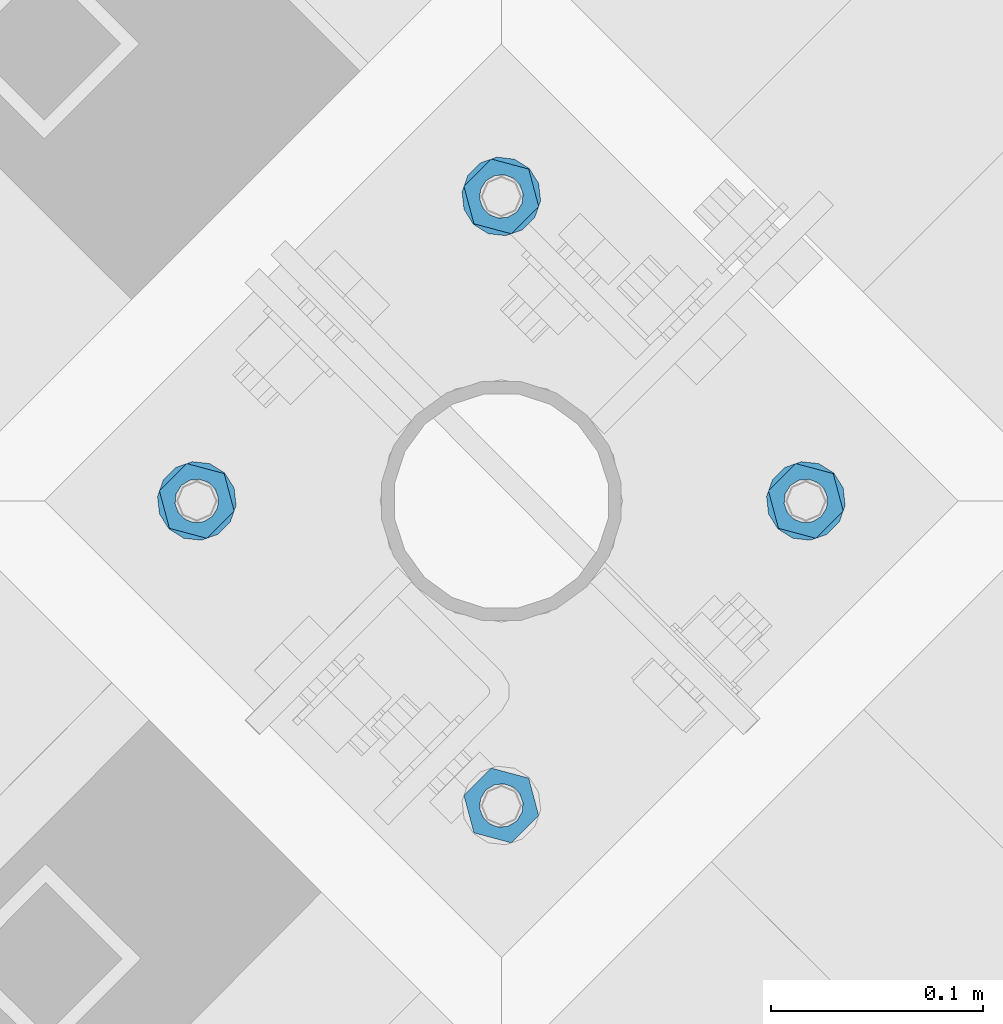
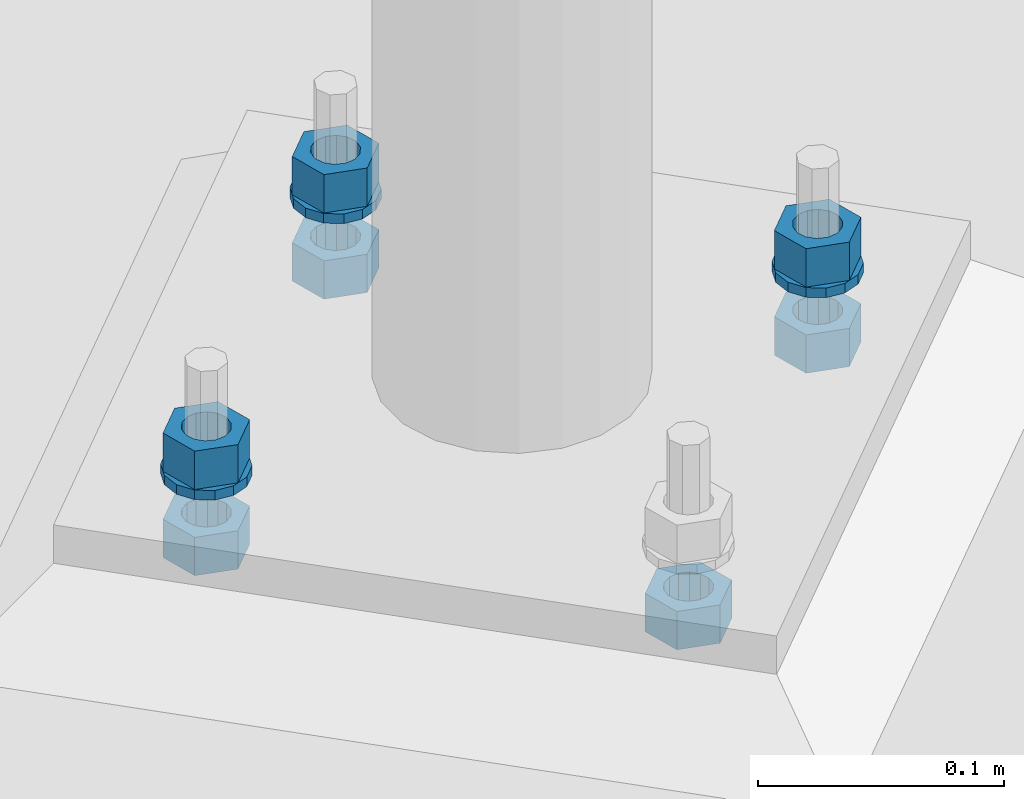
# One storey, part 824 of 975: 10 beams.
"""IFC2X3 building model written with IfcOpenShell, lengths in millimetres."""

from ifc_helpers import new_model, si_unit, frame, origin_with_axes, place, context, subcontext, project, spatial, faceted_brep, material, type_object, element, save


model = new_model("IFC2X3")

# Units and contexts
model_context = context("Model", 3, precision=1e-05, world=origin_with_axes())
body_context = subcontext(model_context, "Body", "Model", "MODEL_VIEW")
ifc_project = project(units=[si_unit("LENGTHUNIT", "METRE", prefix="MILLI"), si_unit("AREAUNIT", "SQUARE_METRE"), si_unit("VOLUMEUNIT", "CUBIC_METRE"), si_unit("MASSUNIT", "GRAM", prefix="KILO"), si_unit("TIMEUNIT", "SECOND"), si_unit("PLANEANGLEUNIT", "RADIAN"), si_unit("SOLIDANGLEUNIT", "STERADIAN"), si_unit("THERMODYNAMICTEMPERATUREUNIT", "DEGREE_CELSIUS"), si_unit("LUMINOUSINTENSITYUNIT", "LUMEN")], contexts=[model_context])

# Site, building, storey
site_placement = place(None, origin_with_axes())
site = spatial("IfcSite", under=ifc_project, at=site_placement, CompositionType="ELEMENT")
building_placement = place(site_placement, origin_with_axes())
building = spatial("IfcBuilding", under=site, at=building_placement, Name="Undefined", CompositionType="ELEMENT")
storey_placement = place(building_placement, origin_with_axes())
storey = spatial("IfcBuildingStorey", under=building, at=storey_placement, Name="Undefined", CompositionType="ELEMENT", Elevation=0.0)

# Beams
ifc_material = material(Name="STEEL/A36")
beam_type_1 = type_object("IfcBeamType", Name="3/4_WASHER", PredefinedType="NOTDEFINED")
beam_1_placement = place(storey_placement, frame((34247.9465946999, 11666.537501079, -242.8875), z_axis=(-0.707106781186601, 0.707106781186494, 2.36468622460961e-14), x_axis=(0.0, 0.0, -1.0)))
element("IfcBeam", 1, at=beam_1_placement, inside=storey, type_object=beam_type_1, material=ifc_material, Name="WASHER", ObjectType="3/4_WASHER", context=body_context, shape_type="Brep", body=[
    faceted_brep([(0.0, -18.6499996185303, 0.0), (0.0, -16.8030690426876, -8.09193156902904), (4.76250000000073, -16.8030690426876, -8.09193156902904), (4.76250000000073, -18.6499996185303, 0.0), (0.0, -11.6280845668225, -14.5811568497838), (4.76250000000073, -11.6280845668225, -14.5811568497838), (0.0, -4.15001533340001, -18.1824051902857), (4.76250000000073, -4.15001533340001, -18.1824051902857), (0.0, 4.15001533340001, -18.1824051902857), (4.76250000000073, 4.15001533340001, -18.1824051902857), (0.0, 11.6280845668234, -14.5811568497838), (4.76250000000073, 11.6280845668234, -14.5811568497838), (0.0, 16.8030690426876, -8.09193156902904), (4.76250000000073, 16.8030690426876, -8.09193156902904), (0.0, 18.6499996185303, 0.0), (4.76250000000073, 18.6499996185303, 0.0), (0.0, 16.8030690426876, 8.09193156902904), (4.76250000000073, 16.8030690426876, 8.09193156902904), (0.0, 11.6280845668225, 14.5811568497838), (4.76250000000073, 11.6280845668225, 14.5811568497838), (0.0, 4.15001533340001, 18.1824051902857), (4.76250000000073, 4.15001533340001, 18.1824051902857), (0.0, -4.15001533340001, 18.1824051902857), (4.76250000000073, -4.15001533340001, 18.1824051902857), (0.0, -11.6280845668234, 14.5811568497838), (4.76250000000073, -11.6280845668234, 14.5811568497838), (0.0, -16.8030690426876, 8.09193156902904), (4.76250000000073, -16.8030690426876, 8.09193156902904), (0.0, 0.0, 10.3199996948242), (0.0, 4.47768005528269, 9.29799844179911), (4.76250000000073, 4.47768005528269, 9.29799844179911), (4.76250000000073, 0.0, 10.3199996948242), (0.0, 8.06850066047446, 6.43441456490817), (4.76250000000073, 8.06850066047446, 6.43441456490817), (0.0, 10.0612557561917, 2.29641597052117), (4.76250000000073, 10.0612557561917, 2.29641597052117), (0.0, 10.0612557561917, -2.29641597052117), (4.76250000000073, 10.0612557561917, -2.29641597052117), (0.0, 8.06850066047446, -6.43441456490814), (4.76250000000073, 8.06850066047446, -6.43441456490814), (0.0, 4.47768005528269, -9.29799844179908), (4.76250000000073, 4.47768005528269, -9.29799844179908), (0.0, 0.0, -10.3199996948242), (4.76250000000073, 0.0, -10.3199996948242), (0.0, -4.47768005528269, -9.29799844179911), (4.76250000000073, -4.47768005528269, -9.29799844179911), (0.0, -8.06850066047446, -6.43441456490817), (4.76250000000073, -8.06850066047446, -6.43441456490817), (0.0, -10.0612557561917, -2.29641597052117), (4.76250000000073, -10.0612557561917, -2.29641597052117), (0.0, -10.0612557561917, 2.29641597052117), (4.76250000000073, -10.0612557561917, 2.29641597052117), (0.0, -8.06850066047446, 6.43441456490814), (4.76250000000073, -8.06850066047446, 6.43441456490814), (0.0, -4.47768005528269, 9.29799844179908), (4.76250000000073, -4.47768005528269, 9.29799844179908)], [[[0, 1, 2, 3]], [[1, 4, 5, 2]], [[4, 6, 7, 5]], [[6, 8, 9, 7]], [[8, 10, 11, 9]], [[10, 12, 13, 11]], [[12, 14, 15, 13]], [[14, 16, 17, 15]], [[16, 18, 19, 17]], [[18, 20, 21, 19]], [[20, 22, 23, 21]], [[22, 24, 25, 23]], [[24, 26, 27, 25]], [[26, 0, 3, 27]], [[28, 29, 30, 31]], [[29, 32, 33, 30]], [[32, 34, 35, 33]], [[34, 36, 37, 35]], [[36, 38, 39, 37]], [[38, 40, 41, 39]], [[40, 42, 43, 41]], [[42, 44, 45, 43]], [[44, 46, 47, 45]], [[46, 48, 49, 47]], [[48, 50, 51, 49]], [[50, 52, 53, 51]], [[52, 54, 55, 53]], [[54, 28, 31, 55]], [[5, 7, 9, 11, 13, 15, 17, 19, 21, 23, 25, 27, 3, 2], [33, 35, 37, 39, 41, 43, 45, 47, 49, 51, 53, 55, 31, 30]], [[26, 24, 22, 20, 18, 16, 14, 12, 10, 8, 6, 4, 1, 0], [54, 52, 50, 48, 46, 44, 42, 40, 38, 36, 34, 32, 29, 28]]]),
])
beam_2_placement = place(storey_placement, frame((33960.5784031422, 11666.537501079, -242.8875), z_axis=(0.707106781186513, -0.707106781186582, 3.1377567211166e-14), x_axis=(0.0, 0.0, -1.0)))
element("IfcBeam", 2, at=beam_2_placement, inside=storey, type_object=beam_type_1, material=ifc_material, Name="WASHER", ObjectType="3/4_WASHER", context=body_context, shape_type="Brep", body=[
    faceted_brep([(0.0, -18.6499996185303, 0.0), (0.0, -16.8030690426876, -8.09193156902904), (4.76250000000073, -16.8030690426876, -8.09193156902904), (4.76250000000073, -18.6499996185303, 0.0), (0.0, -11.6280845668225, -14.5811568497838), (4.76250000000073, -11.6280845668225, -14.5811568497838), (0.0, -4.15001533340001, -18.1824051902857), (4.76250000000073, -4.15001533340001, -18.1824051902857), (0.0, 4.15001533340001, -18.1824051902857), (4.76250000000073, 4.15001533340001, -18.1824051902857), (0.0, 11.6280845668234, -14.5811568497838), (4.76250000000073, 11.6280845668234, -14.5811568497838), (0.0, 16.8030690426876, -8.09193156902904), (4.76250000000073, 16.8030690426876, -8.09193156902904), (0.0, 18.6499996185303, 0.0), (4.76250000000073, 18.6499996185303, 0.0), (0.0, 16.8030690426876, 8.09193156902904), (4.76250000000073, 16.8030690426876, 8.09193156902904), (0.0, 11.6280845668225, 14.5811568497838), (4.76250000000073, 11.6280845668225, 14.5811568497838), (0.0, 4.15001533340001, 18.1824051902857), (4.76250000000073, 4.15001533340001, 18.1824051902857), (0.0, -4.15001533340001, 18.1824051902857), (4.76250000000073, -4.15001533340001, 18.1824051902857), (0.0, -11.6280845668234, 14.5811568497838), (4.76250000000073, -11.6280845668234, 14.5811568497838), (0.0, -16.8030690426876, 8.09193156902904), (4.76250000000073, -16.8030690426876, 8.09193156902904), (0.0, 0.0, 10.3199996948242), (0.0, 4.47768005528269, 9.29799844179911), (4.76250000000073, 4.47768005528269, 9.29799844179911), (4.76250000000073, 0.0, 10.3199996948242), (0.0, 8.06850066047446, 6.43441456490817), (4.76250000000073, 8.06850066047446, 6.43441456490817), (0.0, 10.0612557561917, 2.29641597052117), (4.76250000000073, 10.0612557561917, 2.29641597052117), (0.0, 10.0612557561917, -2.29641597052117), (4.76250000000073, 10.0612557561917, -2.29641597052117), (0.0, 8.06850066047446, -6.43441456490814), (4.76250000000073, 8.06850066047446, -6.43441456490814), (0.0, 4.47768005528269, -9.29799844179908), (4.76250000000073, 4.47768005528269, -9.29799844179908), (0.0, 0.0, -10.3199996948242), (4.76250000000073, 0.0, -10.3199996948242), (0.0, -4.47768005528269, -9.29799844179911), (4.76250000000073, -4.47768005528269, -9.29799844179911), (0.0, -8.06850066047446, -6.43441456490817), (4.76250000000073, -8.06850066047446, -6.43441456490817), (0.0, -10.0612557561917, -2.29641597052117), (4.76250000000073, -10.0612557561917, -2.29641597052117), (0.0, -10.0612557561917, 2.29641597052117), (4.76250000000073, -10.0612557561917, 2.29641597052117), (0.0, -8.06850066047446, 6.43441456490814), (4.76250000000073, -8.06850066047446, 6.43441456490814), (0.0, -4.47768005528269, 9.29799844179908), (4.76250000000073, -4.47768005528269, 9.29799844179908)], [[[0, 1, 2, 3]], [[1, 4, 5, 2]], [[4, 6, 7, 5]], [[6, 8, 9, 7]], [[8, 10, 11, 9]], [[10, 12, 13, 11]], [[12, 14, 15, 13]], [[14, 16, 17, 15]], [[16, 18, 19, 17]], [[18, 20, 21, 19]], [[20, 22, 23, 21]], [[22, 24, 25, 23]], [[24, 26, 27, 25]], [[26, 0, 3, 27]], [[28, 29, 30, 31]], [[29, 32, 33, 30]], [[32, 34, 35, 33]], [[34, 36, 37, 35]], [[36, 38, 39, 37]], [[38, 40, 41, 39]], [[40, 42, 43, 41]], [[42, 44, 45, 43]], [[44, 46, 47, 45]], [[46, 48, 49, 47]], [[48, 50, 51, 49]], [[50, 52, 53, 51]], [[52, 54, 55, 53]], [[54, 28, 31, 55]], [[5, 7, 9, 11, 13, 15, 17, 19, 21, 23, 25, 27, 3, 2], [33, 35, 37, 39, 41, 43, 45, 47, 49, 51, 53, 55, 31, 30]], [[26, 24, 22, 20, 18, 16, 14, 12, 10, 8, 6, 4, 1, 0], [54, 52, 50, 48, 46, 44, 42, 40, 38, 36, 34, 32, 29, 28]]]),
])
beam_3_placement = place(storey_placement, frame((34104.262498921, 11810.2215968582, -242.8875), z_axis=(-0.707106781186601, 0.707106781186494, 2.36468622460961e-14), x_axis=(0.0, 0.0, -1.0)))
element("IfcBeam", 3, at=beam_3_placement, inside=storey, type_object=beam_type_1, material=ifc_material, Name="WASHER", ObjectType="3/4_WASHER", context=body_context, shape_type="Brep", body=[
    faceted_brep([(0.0, -18.6499996185303, 0.0), (0.0, -16.8030690426876, -8.09193156902904), (4.76250000000073, -16.8030690426876, -8.09193156902904), (4.76250000000073, -18.6499996185303, 0.0), (0.0, -11.6280845668225, -14.5811568497838), (4.76250000000073, -11.6280845668225, -14.5811568497838), (0.0, -4.15001533340001, -18.1824051902857), (4.76250000000073, -4.15001533340001, -18.1824051902857), (0.0, 4.15001533340001, -18.1824051902857), (4.76250000000073, 4.15001533340001, -18.1824051902857), (0.0, 11.6280845668234, -14.5811568497838), (4.76250000000073, 11.6280845668234, -14.5811568497838), (0.0, 16.8030690426876, -8.09193156902904), (4.76250000000073, 16.8030690426876, -8.09193156902904), (0.0, 18.6499996185303, 0.0), (4.76250000000073, 18.6499996185303, 0.0), (0.0, 16.8030690426876, 8.09193156902904), (4.76250000000073, 16.8030690426876, 8.09193156902904), (0.0, 11.6280845668225, 14.5811568497838), (4.76250000000073, 11.6280845668225, 14.5811568497838), (0.0, 4.15001533340001, 18.1824051902857), (4.76250000000073, 4.15001533340001, 18.1824051902857), (0.0, -4.15001533340001, 18.1824051902857), (4.76250000000073, -4.15001533340001, 18.1824051902857), (0.0, -11.6280845668234, 14.5811568497838), (4.76250000000073, -11.6280845668234, 14.5811568497838), (0.0, -16.8030690426876, 8.09193156902904), (4.76250000000073, -16.8030690426876, 8.09193156902904), (0.0, 0.0, 10.3199996948242), (0.0, 4.47768005528269, 9.29799844179911), (4.76250000000073, 4.47768005528269, 9.29799844179911), (4.76250000000073, 0.0, 10.3199996948242), (0.0, 8.06850066047446, 6.43441456490817), (4.76250000000073, 8.06850066047446, 6.43441456490817), (0.0, 10.0612557561917, 2.29641597052117), (4.76250000000073, 10.0612557561917, 2.29641597052117), (0.0, 10.0612557561917, -2.29641597052117), (4.76250000000073, 10.0612557561917, -2.29641597052117), (0.0, 8.06850066047446, -6.43441456490814), (4.76250000000073, 8.06850066047446, -6.43441456490814), (0.0, 4.47768005528269, -9.29799844179908), (4.76250000000073, 4.47768005528269, -9.29799844179908), (0.0, 0.0, -10.3199996948242), (4.76250000000073, 0.0, -10.3199996948242), (0.0, -4.47768005528269, -9.29799844179911), (4.76250000000073, -4.47768005528269, -9.29799844179911), (0.0, -8.06850066047446, -6.43441456490817), (4.76250000000073, -8.06850066047446, -6.43441456490817), (0.0, -10.0612557561917, -2.29641597052117), (4.76250000000073, -10.0612557561917, -2.29641597052117), (0.0, -10.0612557561917, 2.29641597052117), (4.76250000000073, -10.0612557561917, 2.29641597052117), (0.0, -8.06850066047446, 6.43441456490814), (4.76250000000073, -8.06850066047446, 6.43441456490814), (0.0, -4.47768005528269, 9.29799844179908), (4.76250000000073, -4.47768005528269, 9.29799844179908)], [[[0, 1, 2, 3]], [[1, 4, 5, 2]], [[4, 6, 7, 5]], [[6, 8, 9, 7]], [[8, 10, 11, 9]], [[10, 12, 13, 11]], [[12, 14, 15, 13]], [[14, 16, 17, 15]], [[16, 18, 19, 17]], [[18, 20, 21, 19]], [[20, 22, 23, 21]], [[22, 24, 25, 23]], [[24, 26, 27, 25]], [[26, 0, 3, 27]], [[28, 29, 30, 31]], [[29, 32, 33, 30]], [[32, 34, 35, 33]], [[34, 36, 37, 35]], [[36, 38, 39, 37]], [[38, 40, 41, 39]], [[40, 42, 43, 41]], [[42, 44, 45, 43]], [[44, 46, 47, 45]], [[46, 48, 49, 47]], [[48, 50, 51, 49]], [[50, 52, 53, 51]], [[52, 54, 55, 53]], [[54, 28, 31, 55]], [[5, 7, 9, 11, 13, 15, 17, 19, 21, 23, 25, 27, 3, 2], [33, 35, 37, 39, 41, 43, 45, 47, 49, 51, 53, 55, 31, 30]], [[26, 24, 22, 20, 18, 16, 14, 12, 10, 8, 6, 4, 1, 0], [54, 52, 50, 48, 46, 44, 42, 40, 38, 36, 34, 32, 29, 28]]]),
])
beam_type_2 = type_object("IfcBeamType", Name="3/4_HEAVY_HEX_NUT", PredefinedType="NOTDEFINED")
beam_4_placement = place(storey_placement, frame((34247.9465946999, 11666.537501079, -223.837500000001), z_axis=(-0.707106781186601, 0.707106781186494, 2.36468622460961e-14), x_axis=(0.0, 0.0, -1.0)))
element("IfcBeam", 4, at=beam_4_placement, inside=storey, type_object=beam_type_2, material=ifc_material, Name="NUT", ObjectType="3/4_HEAVY_HEX_NUT", context=body_context, shape_type="Brep", body=[
    faceted_brep([(0.0, -18.2600002288818, 0.0), (0.0, -9.13000011444092, -15.8100004196167), (19.0499999999993, -9.13000011444092, -15.8100004196167), (19.0499999999993, -18.2600002288818, 0.0), (0.0, 9.13000011444092, -15.8100004196167), (19.0499999999993, 9.13000011444092, -15.8100004196167), (0.0, 18.2600002288818, 0.0), (19.0499999999993, 18.2600002288818, 0.0), (0.0, 9.13000011444092, 15.8100004196167), (19.0499999999993, 9.13000011444092, 15.8100004196167), (0.0, -9.13000011444092, 15.8100004196167), (19.0499999999993, -9.13000011444092, 15.8100004196167), (0.0, 0.0, 10.3199996948242), (0.0, 4.47768005528269, 9.29799844179911), (19.0499999999993, 4.47768005528269, 9.29799844179911), (19.0499999999993, 0.0, 10.3199996948242), (0.0, 8.06850066047446, 6.43441456490817), (19.0499999999993, 8.06850066047446, 6.43441456490817), (0.0, 10.0612557561917, 2.29641597052117), (19.0499999999993, 10.0612557561917, 2.29641597052117), (0.0, 10.0612557561917, -2.29641597052117), (19.0499999999993, 10.0612557561917, -2.29641597052117), (0.0, 8.06850066047446, -6.43441456490814), (19.0499999999993, 8.06850066047446, -6.43441456490814), (0.0, 4.47768005528269, -9.29799844179908), (19.0499999999993, 4.47768005528269, -9.29799844179908), (0.0, 0.0, -10.3199996948242), (19.0499999999993, 0.0, -10.3199996948242), (0.0, -4.47768005528269, -9.29799844179911), (19.0499999999993, -4.47768005528269, -9.29799844179911), (0.0, -8.06850066047446, -6.43441456490817), (19.0499999999993, -8.06850066047446, -6.43441456490817), (0.0, -10.0612557561917, -2.29641597052117), (19.0499999999993, -10.0612557561917, -2.29641597052117), (0.0, -10.0612557561917, 2.29641597052117), (19.0499999999993, -10.0612557561917, 2.29641597052117), (0.0, -8.06850066047446, 6.43441456490814), (19.0499999999993, -8.06850066047446, 6.43441456490814), (0.0, -4.47768005528269, 9.29799844179908), (19.0499999999993, -4.47768005528269, 9.29799844179908)], [[[0, 1, 2, 3]], [[1, 4, 5, 2]], [[4, 6, 7, 5]], [[6, 8, 9, 7]], [[8, 10, 11, 9]], [[10, 0, 3, 11]], [[12, 13, 14, 15]], [[13, 16, 17, 14]], [[16, 18, 19, 17]], [[18, 20, 21, 19]], [[20, 22, 23, 21]], [[22, 24, 25, 23]], [[24, 26, 27, 25]], [[26, 28, 29, 27]], [[28, 30, 31, 29]], [[30, 32, 33, 31]], [[32, 34, 35, 33]], [[34, 36, 37, 35]], [[36, 38, 39, 37]], [[38, 12, 15, 39]], [[5, 7, 9, 11, 3, 2], [17, 19, 21, 23, 25, 27, 29, 31, 33, 35, 37, 39, 15, 14]], [[10, 8, 6, 4, 1, 0], [38, 36, 34, 32, 30, 28, 26, 24, 22, 20, 18, 16, 13, 12]]]),
])
beam_5_placement = place(storey_placement, frame((33960.5784031422, 11666.537501079, -223.837500000001), z_axis=(0.707106781186513, -0.707106781186582, 3.1377567211166e-14), x_axis=(0.0, 0.0, -1.0)))
element("IfcBeam", 5, at=beam_5_placement, inside=storey, type_object=beam_type_2, material=ifc_material, Name="NUT", ObjectType="3/4_HEAVY_HEX_NUT", context=body_context, shape_type="Brep", body=[
    faceted_brep([(0.0, -18.2600002288818, 0.0), (0.0, -9.13000011444092, -15.8100004196167), (19.0499999999993, -9.13000011444092, -15.8100004196167), (19.0499999999993, -18.2600002288818, 0.0), (0.0, 9.13000011444092, -15.8100004196167), (19.0499999999993, 9.13000011444092, -15.8100004196167), (0.0, 18.2600002288818, 0.0), (19.0499999999993, 18.2600002288818, 0.0), (0.0, 9.13000011444092, 15.8100004196167), (19.0499999999993, 9.13000011444092, 15.8100004196167), (0.0, -9.13000011444092, 15.8100004196167), (19.0499999999993, -9.13000011444092, 15.8100004196167), (0.0, 0.0, 10.3199996948242), (0.0, 4.47768005528269, 9.29799844179911), (19.0499999999993, 4.47768005528269, 9.29799844179911), (19.0499999999993, 0.0, 10.3199996948242), (0.0, 8.06850066047446, 6.43441456490817), (19.0499999999993, 8.06850066047446, 6.43441456490817), (0.0, 10.0612557561917, 2.29641597052117), (19.0499999999993, 10.0612557561917, 2.29641597052117), (0.0, 10.0612557561917, -2.29641597052117), (19.0499999999993, 10.0612557561917, -2.29641597052117), (0.0, 8.06850066047446, -6.43441456490814), (19.0499999999993, 8.06850066047446, -6.43441456490814), (0.0, 4.47768005528269, -9.29799844179908), (19.0499999999993, 4.47768005528269, -9.29799844179908), (0.0, 0.0, -10.3199996948242), (19.0499999999993, 0.0, -10.3199996948242), (0.0, -4.47768005528269, -9.29799844179911), (19.0499999999993, -4.47768005528269, -9.29799844179911), (0.0, -8.06850066047446, -6.43441456490817), (19.0499999999993, -8.06850066047446, -6.43441456490817), (0.0, -10.0612557561917, -2.29641597052117), (19.0499999999993, -10.0612557561917, -2.29641597052117), (0.0, -10.0612557561917, 2.29641597052117), (19.0499999999993, -10.0612557561917, 2.29641597052117), (0.0, -8.06850066047446, 6.43441456490814), (19.0499999999993, -8.06850066047446, 6.43441456490814), (0.0, -4.47768005528269, 9.29799844179908), (19.0499999999993, -4.47768005528269, 9.29799844179908)], [[[0, 1, 2, 3]], [[1, 4, 5, 2]], [[4, 6, 7, 5]], [[6, 8, 9, 7]], [[8, 10, 11, 9]], [[10, 0, 3, 11]], [[12, 13, 14, 15]], [[13, 16, 17, 14]], [[16, 18, 19, 17]], [[18, 20, 21, 19]], [[20, 22, 23, 21]], [[22, 24, 25, 23]], [[24, 26, 27, 25]], [[26, 28, 29, 27]], [[28, 30, 31, 29]], [[30, 32, 33, 31]], [[32, 34, 35, 33]], [[34, 36, 37, 35]], [[36, 38, 39, 37]], [[38, 12, 15, 39]], [[5, 7, 9, 11, 3, 2], [17, 19, 21, 23, 25, 27, 29, 31, 33, 35, 37, 39, 15, 14]], [[10, 8, 6, 4, 1, 0], [38, 36, 34, 32, 30, 28, 26, 24, 22, 20, 18, 16, 13, 12]]]),
])
beam_6_placement = place(storey_placement, frame((34104.262498921, 11810.2215968582, -223.837500000001), z_axis=(-0.707106781186601, 0.707106781186494, 2.36468622460961e-14), x_axis=(0.0, 0.0, -1.0)))
element("IfcBeam", 6, at=beam_6_placement, inside=storey, type_object=beam_type_2, material=ifc_material, Name="NUT", ObjectType="3/4_HEAVY_HEX_NUT", context=body_context, shape_type="Brep", body=[
    faceted_brep([(0.0, -18.2600002288818, 0.0), (0.0, -9.13000011444092, -15.8100004196167), (19.0499999999993, -9.13000011444092, -15.8100004196167), (19.0499999999993, -18.2600002288818, 0.0), (0.0, 9.13000011444092, -15.8100004196167), (19.0499999999993, 9.13000011444092, -15.8100004196167), (0.0, 18.2600002288818, 0.0), (19.0499999999993, 18.2600002288818, 0.0), (0.0, 9.13000011444092, 15.8100004196167), (19.0499999999993, 9.13000011444092, 15.8100004196167), (0.0, -9.13000011444092, 15.8100004196167), (19.0499999999993, -9.13000011444092, 15.8100004196167), (0.0, 0.0, 10.3199996948242), (0.0, 4.47768005528269, 9.29799844179911), (19.0499999999993, 4.47768005528269, 9.29799844179911), (19.0499999999993, 0.0, 10.3199996948242), (0.0, 8.06850066047446, 6.43441456490817), (19.0499999999993, 8.06850066047446, 6.43441456490817), (0.0, 10.0612557561917, 2.29641597052117), (19.0499999999993, 10.0612557561917, 2.29641597052117), (0.0, 10.0612557561917, -2.29641597052117), (19.0499999999993, 10.0612557561917, -2.29641597052117), (0.0, 8.06850066047446, -6.43441456490814), (19.0499999999993, 8.06850066047446, -6.43441456490814), (0.0, 4.47768005528269, -9.29799844179908), (19.0499999999993, 4.47768005528269, -9.29799844179908), (0.0, 0.0, -10.3199996948242), (19.0499999999993, 0.0, -10.3199996948242), (0.0, -4.47768005528269, -9.29799844179911), (19.0499999999993, -4.47768005528269, -9.29799844179911), (0.0, -8.06850066047446, -6.43441456490817), (19.0499999999993, -8.06850066047446, -6.43441456490817), (0.0, -10.0612557561917, -2.29641597052117), (19.0499999999993, -10.0612557561917, -2.29641597052117), (0.0, -10.0612557561917, 2.29641597052117), (19.0499999999993, -10.0612557561917, 2.29641597052117), (0.0, -8.06850066047446, 6.43441456490814), (19.0499999999993, -8.06850066047446, 6.43441456490814), (0.0, -4.47768005528269, 9.29799844179908), (19.0499999999993, -4.47768005528269, 9.29799844179908)], [[[0, 1, 2, 3]], [[1, 4, 5, 2]], [[4, 6, 7, 5]], [[6, 8, 9, 7]], [[8, 10, 11, 9]], [[10, 0, 3, 11]], [[12, 13, 14, 15]], [[13, 16, 17, 14]], [[16, 18, 19, 17]], [[18, 20, 21, 19]], [[20, 22, 23, 21]], [[22, 24, 25, 23]], [[24, 26, 27, 25]], [[26, 28, 29, 27]], [[28, 30, 31, 29]], [[30, 32, 33, 31]], [[32, 34, 35, 33]], [[34, 36, 37, 35]], [[36, 38, 39, 37]], [[38, 12, 15, 39]], [[5, 7, 9, 11, 3, 2], [17, 19, 21, 23, 25, 27, 29, 31, 33, 35, 37, 39, 15, 14]], [[10, 8, 6, 4, 1, 0], [38, 36, 34, 32, 30, 28, 26, 24, 22, 20, 18, 16, 13, 12]]]),
])
beam_7_placement = place(storey_placement, frame((34104.262498921, 11522.8534052998, -266.7), z_axis=(0.707106781186513, -0.707106781186582, 3.1377567211166e-14), x_axis=(0.0, 0.0, -1.0)))
element("IfcBeam", 7, at=beam_7_placement, inside=storey, type_object=beam_type_2, material=ifc_material, Name="NUT", ObjectType="3/4_HEAVY_HEX_NUT", context=body_context, shape_type="Brep", body=[
    faceted_brep([(0.0, -18.2600002288818, 0.0), (0.0, -9.13000011444092, -15.8100004196167), (19.0499999999993, -9.13000011444092, -15.8100004196167), (19.0499999999993, -18.2600002288818, 0.0), (0.0, 9.13000011444092, -15.8100004196167), (19.0499999999993, 9.13000011444092, -15.8100004196167), (0.0, 18.2600002288818, 0.0), (19.0499999999993, 18.2600002288818, 0.0), (0.0, 9.13000011444092, 15.8100004196167), (19.0499999999993, 9.13000011444092, 15.8100004196167), (0.0, -9.13000011444092, 15.8100004196167), (19.0499999999993, -9.13000011444092, 15.8100004196167), (0.0, 0.0, 10.3199996948242), (0.0, 4.47768005528269, 9.29799844179911), (19.0499999999993, 4.47768005528269, 9.29799844179911), (19.0499999999993, 0.0, 10.3199996948242), (0.0, 8.06850066047446, 6.43441456490817), (19.0499999999993, 8.06850066047446, 6.43441456490817), (0.0, 10.0612557561917, 2.29641597052117), (19.0499999999993, 10.0612557561917, 2.29641597052117), (0.0, 10.0612557561917, -2.29641597052117), (19.0499999999993, 10.0612557561917, -2.29641597052117), (0.0, 8.06850066047446, -6.43441456490814), (19.0499999999993, 8.06850066047446, -6.43441456490814), (0.0, 4.47768005528269, -9.29799844179908), (19.0499999999993, 4.47768005528269, -9.29799844179908), (0.0, 0.0, -10.3199996948242), (19.0499999999993, 0.0, -10.3199996948242), (0.0, -4.47768005528269, -9.29799844179911), (19.0499999999993, -4.47768005528269, -9.29799844179911), (0.0, -8.06850066047446, -6.43441456490817), (19.0499999999993, -8.06850066047446, -6.43441456490817), (0.0, -10.0612557561917, -2.29641597052117), (19.0499999999993, -10.0612557561917, -2.29641597052117), (0.0, -10.0612557561917, 2.29641597052117), (19.0499999999993, -10.0612557561917, 2.29641597052117), (0.0, -8.06850066047446, 6.43441456490814), (19.0499999999993, -8.06850066047446, 6.43441456490814), (0.0, -4.47768005528269, 9.29799844179908), (19.0499999999993, -4.47768005528269, 9.29799844179908)], [[[0, 1, 2, 3]], [[1, 4, 5, 2]], [[4, 6, 7, 5]], [[6, 8, 9, 7]], [[8, 10, 11, 9]], [[10, 0, 3, 11]], [[12, 13, 14, 15]], [[13, 16, 17, 14]], [[16, 18, 19, 17]], [[18, 20, 21, 19]], [[20, 22, 23, 21]], [[22, 24, 25, 23]], [[24, 26, 27, 25]], [[26, 28, 29, 27]], [[28, 30, 31, 29]], [[30, 32, 33, 31]], [[32, 34, 35, 33]], [[34, 36, 37, 35]], [[36, 38, 39, 37]], [[38, 12, 15, 39]], [[5, 7, 9, 11, 3, 2], [17, 19, 21, 23, 25, 27, 29, 31, 33, 35, 37, 39, 15, 14]], [[10, 8, 6, 4, 1, 0], [38, 36, 34, 32, 30, 28, 26, 24, 22, 20, 18, 16, 13, 12]]]),
])
beam_8_placement = place(storey_placement, frame((34247.9465946999, 11666.537501079, -266.7), z_axis=(-0.707106781186601, 0.707106781186494, 2.36468622460961e-14), x_axis=(0.0, 0.0, -1.0)))
element("IfcBeam", 8, at=beam_8_placement, inside=storey, type_object=beam_type_2, material=ifc_material, Name="NUT", ObjectType="3/4_HEAVY_HEX_NUT", context=body_context, shape_type="Brep", body=[
    faceted_brep([(0.0, -18.2600002288818, 0.0), (0.0, -9.13000011444092, -15.8100004196167), (19.0499999999993, -9.13000011444092, -15.8100004196167), (19.0499999999993, -18.2600002288818, 0.0), (0.0, 9.13000011444092, -15.8100004196167), (19.0499999999993, 9.13000011444092, -15.8100004196167), (0.0, 18.2600002288818, 0.0), (19.0499999999993, 18.2600002288818, 0.0), (0.0, 9.13000011444092, 15.8100004196167), (19.0499999999993, 9.13000011444092, 15.8100004196167), (0.0, -9.13000011444092, 15.8100004196167), (19.0499999999993, -9.13000011444092, 15.8100004196167), (0.0, 0.0, 10.3199996948242), (0.0, 4.47768005528269, 9.29799844179911), (19.0499999999993, 4.47768005528269, 9.29799844179911), (19.0499999999993, 0.0, 10.3199996948242), (0.0, 8.06850066047446, 6.43441456490817), (19.0499999999993, 8.06850066047446, 6.43441456490817), (0.0, 10.0612557561917, 2.29641597052117), (19.0499999999993, 10.0612557561917, 2.29641597052117), (0.0, 10.0612557561917, -2.29641597052117), (19.0499999999993, 10.0612557561917, -2.29641597052117), (0.0, 8.06850066047446, -6.43441456490814), (19.0499999999993, 8.06850066047446, -6.43441456490814), (0.0, 4.47768005528269, -9.29799844179908), (19.0499999999993, 4.47768005528269, -9.29799844179908), (0.0, 0.0, -10.3199996948242), (19.0499999999993, 0.0, -10.3199996948242), (0.0, -4.47768005528269, -9.29799844179911), (19.0499999999993, -4.47768005528269, -9.29799844179911), (0.0, -8.06850066047446, -6.43441456490817), (19.0499999999993, -8.06850066047446, -6.43441456490817), (0.0, -10.0612557561917, -2.29641597052117), (19.0499999999993, -10.0612557561917, -2.29641597052117), (0.0, -10.0612557561917, 2.29641597052117), (19.0499999999993, -10.0612557561917, 2.29641597052117), (0.0, -8.06850066047446, 6.43441456490814), (19.0499999999993, -8.06850066047446, 6.43441456490814), (0.0, -4.47768005528269, 9.29799844179908), (19.0499999999993, -4.47768005528269, 9.29799844179908)], [[[0, 1, 2, 3]], [[1, 4, 5, 2]], [[4, 6, 7, 5]], [[6, 8, 9, 7]], [[8, 10, 11, 9]], [[10, 0, 3, 11]], [[12, 13, 14, 15]], [[13, 16, 17, 14]], [[16, 18, 19, 17]], [[18, 20, 21, 19]], [[20, 22, 23, 21]], [[22, 24, 25, 23]], [[24, 26, 27, 25]], [[26, 28, 29, 27]], [[28, 30, 31, 29]], [[30, 32, 33, 31]], [[32, 34, 35, 33]], [[34, 36, 37, 35]], [[36, 38, 39, 37]], [[38, 12, 15, 39]], [[5, 7, 9, 11, 3, 2], [17, 19, 21, 23, 25, 27, 29, 31, 33, 35, 37, 39, 15, 14]], [[10, 8, 6, 4, 1, 0], [38, 36, 34, 32, 30, 28, 26, 24, 22, 20, 18, 16, 13, 12]]]),
])
beam_9_placement = place(storey_placement, frame((33960.5784031422, 11666.537501079, -266.7), z_axis=(0.707106781186513, -0.707106781186582, 3.1377567211166e-14), x_axis=(0.0, 0.0, -1.0)))
element("IfcBeam", 9, at=beam_9_placement, inside=storey, type_object=beam_type_2, material=ifc_material, Name="NUT", ObjectType="3/4_HEAVY_HEX_NUT", context=body_context, shape_type="Brep", body=[
    faceted_brep([(0.0, -18.2600002288818, 0.0), (0.0, -9.13000011444092, -15.8100004196167), (19.0499999999993, -9.13000011444092, -15.8100004196167), (19.0499999999993, -18.2600002288818, 0.0), (0.0, 9.13000011444092, -15.8100004196167), (19.0499999999993, 9.13000011444092, -15.8100004196167), (0.0, 18.2600002288818, 0.0), (19.0499999999993, 18.2600002288818, 0.0), (0.0, 9.13000011444092, 15.8100004196167), (19.0499999999993, 9.13000011444092, 15.8100004196167), (0.0, -9.13000011444092, 15.8100004196167), (19.0499999999993, -9.13000011444092, 15.8100004196167), (0.0, 0.0, 10.3199996948242), (0.0, 4.47768005528269, 9.29799844179911), (19.0499999999993, 4.47768005528269, 9.29799844179911), (19.0499999999993, 0.0, 10.3199996948242), (0.0, 8.06850066047446, 6.43441456490817), (19.0499999999993, 8.06850066047446, 6.43441456490817), (0.0, 10.0612557561917, 2.29641597052117), (19.0499999999993, 10.0612557561917, 2.29641597052117), (0.0, 10.0612557561917, -2.29641597052117), (19.0499999999993, 10.0612557561917, -2.29641597052117), (0.0, 8.06850066047446, -6.43441456490814), (19.0499999999993, 8.06850066047446, -6.43441456490814), (0.0, 4.47768005528269, -9.29799844179908), (19.0499999999993, 4.47768005528269, -9.29799844179908), (0.0, 0.0, -10.3199996948242), (19.0499999999993, 0.0, -10.3199996948242), (0.0, -4.47768005528269, -9.29799844179911), (19.0499999999993, -4.47768005528269, -9.29799844179911), (0.0, -8.06850066047446, -6.43441456490817), (19.0499999999993, -8.06850066047446, -6.43441456490817), (0.0, -10.0612557561917, -2.29641597052117), (19.0499999999993, -10.0612557561917, -2.29641597052117), (0.0, -10.0612557561917, 2.29641597052117), (19.0499999999993, -10.0612557561917, 2.29641597052117), (0.0, -8.06850066047446, 6.43441456490814), (19.0499999999993, -8.06850066047446, 6.43441456490814), (0.0, -4.47768005528269, 9.29799844179908), (19.0499999999993, -4.47768005528269, 9.29799844179908)], [[[0, 1, 2, 3]], [[1, 4, 5, 2]], [[4, 6, 7, 5]], [[6, 8, 9, 7]], [[8, 10, 11, 9]], [[10, 0, 3, 11]], [[12, 13, 14, 15]], [[13, 16, 17, 14]], [[16, 18, 19, 17]], [[18, 20, 21, 19]], [[20, 22, 23, 21]], [[22, 24, 25, 23]], [[24, 26, 27, 25]], [[26, 28, 29, 27]], [[28, 30, 31, 29]], [[30, 32, 33, 31]], [[32, 34, 35, 33]], [[34, 36, 37, 35]], [[36, 38, 39, 37]], [[38, 12, 15, 39]], [[5, 7, 9, 11, 3, 2], [17, 19, 21, 23, 25, 27, 29, 31, 33, 35, 37, 39, 15, 14]], [[10, 8, 6, 4, 1, 0], [38, 36, 34, 32, 30, 28, 26, 24, 22, 20, 18, 16, 13, 12]]]),
])
beam_10_placement = place(storey_placement, frame((34104.262498921, 11810.2215968582, -266.7), z_axis=(-0.707106781186601, 0.707106781186494, 2.36468622460961e-14), x_axis=(0.0, 0.0, -1.0)))
element("IfcBeam", 10, at=beam_10_placement, inside=storey, type_object=beam_type_2, material=ifc_material, Name="NUT", ObjectType="3/4_HEAVY_HEX_NUT", context=body_context, shape_type="Brep", body=[
    faceted_brep([(0.0, -18.2600002288818, 0.0), (0.0, -9.13000011444092, -15.8100004196167), (19.0499999999993, -9.13000011444092, -15.8100004196167), (19.0499999999993, -18.2600002288818, 0.0), (0.0, 9.13000011444092, -15.8100004196167), (19.0499999999993, 9.13000011444092, -15.8100004196167), (0.0, 18.2600002288818, 0.0), (19.0499999999993, 18.2600002288818, 0.0), (0.0, 9.13000011444092, 15.8100004196167), (19.0499999999993, 9.13000011444092, 15.8100004196167), (0.0, -9.13000011444092, 15.8100004196167), (19.0499999999993, -9.13000011444092, 15.8100004196167), (0.0, 0.0, 10.3199996948242), (0.0, 4.47768005528269, 9.29799844179911), (19.0499999999993, 4.47768005528269, 9.29799844179911), (19.0499999999993, 0.0, 10.3199996948242), (0.0, 8.06850066047446, 6.43441456490817), (19.0499999999993, 8.06850066047446, 6.43441456490817), (0.0, 10.0612557561917, 2.29641597052117), (19.0499999999993, 10.0612557561917, 2.29641597052117), (0.0, 10.0612557561917, -2.29641597052117), (19.0499999999993, 10.0612557561917, -2.29641597052117), (0.0, 8.06850066047446, -6.43441456490814), (19.0499999999993, 8.06850066047446, -6.43441456490814), (0.0, 4.47768005528269, -9.29799844179908), (19.0499999999993, 4.47768005528269, -9.29799844179908), (0.0, 0.0, -10.3199996948242), (19.0499999999993, 0.0, -10.3199996948242), (0.0, -4.47768005528269, -9.29799844179911), (19.0499999999993, -4.47768005528269, -9.29799844179911), (0.0, -8.06850066047446, -6.43441456490817), (19.0499999999993, -8.06850066047446, -6.43441456490817), (0.0, -10.0612557561917, -2.29641597052117), (19.0499999999993, -10.0612557561917, -2.29641597052117), (0.0, -10.0612557561917, 2.29641597052117), (19.0499999999993, -10.0612557561917, 2.29641597052117), (0.0, -8.06850066047446, 6.43441456490814), (19.0499999999993, -8.06850066047446, 6.43441456490814), (0.0, -4.47768005528269, 9.29799844179908), (19.0499999999993, -4.47768005528269, 9.29799844179908)], [[[0, 1, 2, 3]], [[1, 4, 5, 2]], [[4, 6, 7, 5]], [[6, 8, 9, 7]], [[8, 10, 11, 9]], [[10, 0, 3, 11]], [[12, 13, 14, 15]], [[13, 16, 17, 14]], [[16, 18, 19, 17]], [[18, 20, 21, 19]], [[20, 22, 23, 21]], [[22, 24, 25, 23]], [[24, 26, 27, 25]], [[26, 28, 29, 27]], [[28, 30, 31, 29]], [[30, 32, 33, 31]], [[32, 34, 35, 33]], [[34, 36, 37, 35]], [[36, 38, 39, 37]], [[38, 12, 15, 39]], [[5, 7, 9, 11, 3, 2], [17, 19, 21, 23, 25, 27, 29, 31, 33, 35, 37, 39, 15, 14]], [[10, 8, 6, 4, 1, 0], [38, 36, 34, 32, 30, 28, 26, 24, 22, 20, 18, 16, 13, 12]]]),
])

save(model, "model.ifc")
